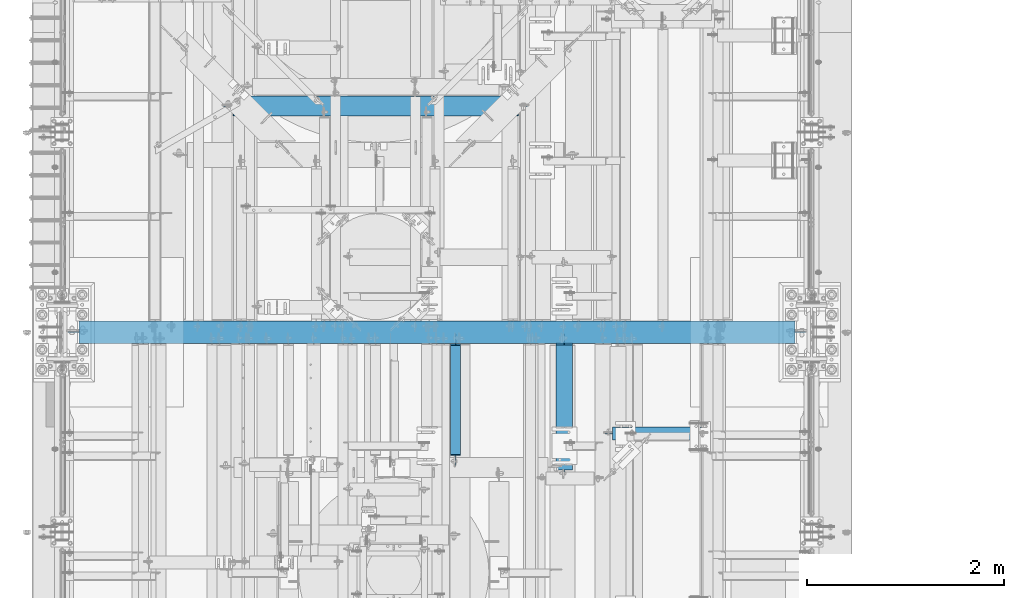
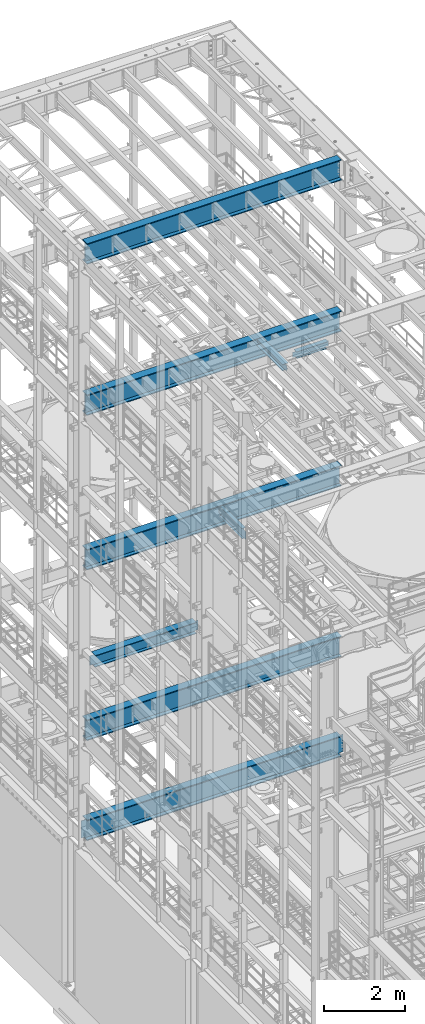
# One storey, part 1045 of 1876: 9 beams, 9 elements without a shape of their own.
"""IFC2X3 building model written with IfcOpenShell, lengths in millimetres."""

from ifc_helpers import new_model, si_unit, frame, origin_with_axes, place, context, subcontext, project, spatial, faceted_brep, material, type_object, element, aggregate, save


model = new_model("IFC2X3")

# Units and contexts
model_context = context("Model", 3, precision=1e-05, world=origin_with_axes())
body_context = subcontext(model_context, "Body", "Model", "MODEL_VIEW")
ifc_project = project(units=[si_unit("LENGTHUNIT", "METRE", prefix="MILLI"), si_unit("AREAUNIT", "SQUARE_METRE"), si_unit("VOLUMEUNIT", "CUBIC_METRE"), si_unit("MASSUNIT", "GRAM", prefix="KILO"), si_unit("TIMEUNIT", "SECOND"), si_unit("PLANEANGLEUNIT", "RADIAN"), si_unit("SOLIDANGLEUNIT", "STERADIAN"), si_unit("THERMODYNAMICTEMPERATUREUNIT", "DEGREE_CELSIUS"), si_unit("LUMINOUSINTENSITYUNIT", "LUMEN")], contexts=[model_context])

# Site, building, storey
site_placement = place(None, origin_with_axes())
site = spatial("IfcSite", under=ifc_project, at=site_placement, CompositionType="ELEMENT")
building_placement = place(site_placement, origin_with_axes())
building = spatial("IfcBuilding", under=site, at=building_placement, Name="Undefined", CompositionType="ELEMENT")
storey_placement = place(building_placement, origin_with_axes())
storey = spatial("IfcBuildingStorey", under=building, at=storey_placement, Name="Undefined", CompositionType="ELEMENT", Elevation=0.0)

# Assembly, beam
assembly_1_placement = place(storey_placement, origin_with_axes())
assembly_1 = element("IfcElementAssembly", 1, at=assembly_1_placement, inside=storey, Name="BEAM", AssemblyPlace="NOTDEFINED", PredefinedType="RIGID_FRAME")
ifc_material = material(Name="STEEL/A992")
beam_type_1 = type_object("IfcBeamType", Name="W8X24", PredefinedType="NOTDEFINED")
beam_1_placement = place(assembly_1_placement, frame((5105.39901450963, 6133.50589599609, 17883.1875), z_axis=(0.0, 0.0, 1.0), x_axis=(0.0, 1.0, 0.0)))
beam_1 = element("IfcBeam", 2, at=beam_1_placement, type_object=beam_type_1, material=ifc_material, Name="BEAM", ObjectType="W8X24", context=body_context, shape_type="Brep", body=[
    faceted_brep([(1374.57535400391, -82.5500000000002, -100.012500000001), (1374.57535400391, 82.5500000000002, -100.012500000001), (1374.57535400391, 82.5500000000002, -93.662499809263), (1374.57535400391, -82.5500000000002, -93.662499809263), (1375.2069007324, -3.17500000000018, -90.4874999999993), (1375.2069007324, -82.5500000000002, -90.4874999999993), (1375.2069007324, 82.5500000000002, -90.4874999999993), (1375.2069007324, 3.17500000000018, -90.4874999999993), (1375.54208392649, 3.17500000000018, -88.8024202912165), (1375.54208392649, -3.17500000000018, -88.8024202912165), (1378.29509782697, 3.17500000000018, -84.6822438230629), (1378.29509782697, -3.17500000000018, -84.6822438230629), (1382.41527429513, 3.17500000000018, -81.9292299225854), (1382.41527429513, -3.17500000000018, -81.9292299225854), (1387.27535381317, 3.17500000000018, -80.9624999999978), (1387.27535381317, -3.17500000000018, -80.9624999999978), (1466.65035400391, -3.17500000000018, -80.9624999999978), (1466.65035400391, 3.17500000000018, -80.9624999999978), (85.7249999999985, 3.17500000000018, 90.4874999999993), (85.7249999999985, 82.5500000000002, 90.4874999999993), (1358.70035400391, 82.5500000000002, 90.4874999999993), (1358.70035400391, 3.17500000000018, 90.4874999999993), (107.949999999998, -3.17500000000018, -87.3124998092644), (107.949999999998, 3.17500000000018, -87.3124998092644), (107.950000000001, 3.17500000000018, -90.48749980926), (107.949999999998, 82.5500000000002, -90.4874999999993), (107.949999999998, 82.5500000000002, -100.012500000001), (107.949999999998, -82.5500000000002, -100.012500000001), (107.949999999998, -82.5500000000002, -90.4874999999993), (107.950000000001, -3.17500000000018, -90.48749980926), (106.98327007741, -3.17500000000018, -82.452420291218), (106.98327007741, 3.17500000000018, -82.452420291218), (104.230256176932, -3.17500000000018, -78.3322438230643), (104.230256176932, 3.17500000000018, -78.3322438230643), (100.110079708778, -3.17500000000018, -75.5792299225868), (100.110079708778, 3.17500000000018, -75.5792299225868), (95.2500001907329, -3.17500000000018, -74.6124999999993), (95.2500001907329, 3.17500000000018, -74.6124999999993), (15.8749999999982, -3.17500000000018, -74.6124999999993), (15.8749999999982, 3.17500000000018, -74.6124999999993), (15.875, -3.17500000000018, 74.6125000000029), (15.875, 3.17500000000018, 74.6125000000029), (73.0250001907334, -3.17500000000018, 74.6124999999993), (73.0250001907334, 3.17500000000018, 74.6124999999993), (77.8850797087789, -3.17500000000018, 75.5792299225868), (77.8850797087789, 3.17500000000018, 75.5792299225868), (82.0052561769326, -3.17500000000018, 78.3322438230643), (82.0052561769326, 3.17500000000018, 78.3322438230643), (84.758270077411, -3.17500000000018, 82.452420291218), (84.758270077411, 3.17500000000018, 82.452420291218), (85.7249999999985, -3.17500000000018, 87.3124998092644), (85.7249999999985, 3.17500000000018, 87.3124998092644), (85.7249999999985, -82.5500000000002, 100.012500000001), (85.7249999999985, 82.5500000000002, 100.012500000001), (85.7249999999985, -3.17500000000018, 90.4874999999993), (85.7249999999985, -82.5500000000002, 90.4874999999993), (1358.70035400391, -3.17500000000018, 90.4874999999993), (1358.70035400391, -82.5500000000002, 90.4874999999993), (1358.70035400391, -82.5500000000002, 100.012500000001), (1358.70035400391, 82.5500000000002, 100.012500000001), (1358.70035400391, -3.17500000000018, 74.612499809271), (1358.70035400391, 3.17500000000018, 74.612499809271), (1359.66708392649, -3.17500000000018, 69.7524202912246), (1359.66708392649, 3.17500000000018, 69.7524202912246), (1362.42009782697, -3.17500000000018, 65.6322438230709), (1362.42009782697, 3.17500000000018, 65.6322438230709), (1366.54027429513, -3.17500000000018, 62.8792299225934), (1366.54027429513, 3.17500000000018, 62.8792299225934), (1371.40035381317, -3.17500000000018, 61.9125000000058), (1371.40035381317, 3.17500000000018, 61.9125000000058), (1466.65035400391, -3.17500000000018, 61.9125000000058), (1466.65035400391, 3.17500000000018, 61.9125000000058)], [[[0, 1, 2, 3]], [[4, 5, 3, 2, 6, 7, 8, 9]], [[9, 8, 10, 11]], [[11, 10, 12, 13]], [[13, 12, 14, 15]], [[16, 15, 14, 17]], [[18, 19, 20, 21]], [[22, 23, 24, 25, 26, 27, 28, 29]], [[30, 31, 23, 22]], [[32, 33, 31, 30]], [[34, 35, 33, 32]], [[36, 37, 35, 34]], [[38, 39, 37, 36]], [[40, 41, 39, 38]], [[42, 43, 41, 40]], [[44, 45, 43, 42]], [[46, 47, 45, 44]], [[48, 49, 47, 46]], [[50, 51, 49, 48]], [[52, 53, 19, 18, 51, 50, 54, 55]], [[55, 54, 56, 57]], [[52, 55, 57, 58]], [[53, 52, 58, 59]], [[19, 53, 59, 20]], [[58, 57, 56, 60, 61, 21, 20, 59]], [[62, 63, 61, 60]], [[64, 65, 63, 62]], [[66, 67, 65, 64]], [[68, 69, 67, 66]], [[70, 71, 69, 68]], [[71, 70, 16, 17]], [[12, 10, 8, 7, 24, 23, 31, 33, 35, 37, 39, 41, 43, 45, 47, 49, 51, 18, 21, 61, 63, 65, 67, 69, 71, 17, 14]], [[25, 24, 7, 6]], [[1, 26, 25, 6, 2]], [[27, 26, 1, 0]], [[28, 27, 0, 3, 5]], [[29, 28, 5, 4]], [[70, 68, 66, 64, 62, 60, 56, 54, 50, 48, 46, 44, 42, 40, 38, 36, 34, 32, 30, 22, 29, 4, 9, 11, 13, 15, 16]]]),
])
aggregate(assembly_1, [beam_1])

assembly_2_placement = place(storey_placement, origin_with_axes())
assembly_2 = element("IfcElementAssembly", 3, at=assembly_2_placement, inside=storey, Name="BEAM", AssemblyPlace="NOTDEFINED", PredefinedType="RIGID_FRAME")
beam_type_2 = type_object("IfcBeamType", Name="W12X16", PredefinedType="NOTDEFINED")
beam_2_placement = place(assembly_2_placement, frame((4000.5, 6115.05, 13157.2), z_axis=(0.0, 0.0, 1.0), x_axis=(0.0, 1.0, 0.0)))
beam_2 = element("IfcBeam", 4, at=beam_2_placement, type_object=beam_type_2, material=ifc_material, Name="BEAM", ObjectType="W12X16", context=body_context, shape_type="Brep", body=[
    faceted_brep([(148.431250000001, -3.17500000000018, -127.0), (148.431250000001, 3.17500000000018, -127.0), (237.331250190735, 3.17500000000018, -127.0), (237.331250190735, -3.17500000000018, -127.0), (242.19132970878, 3.17500000000018, -127.966729922588), (242.19132970878, -3.17500000000018, -127.966729922588), (246.311506176934, 3.17500000000018, -130.719743823067), (246.311506176934, -3.17500000000018, -130.719743823067), (249.064520077412, 3.17500000000018, -134.839920291221), (249.064520077412, -3.17500000000018, -134.839920291221), (250.03125, -3.17500000000018, -139.699999809265), (250.03125, 3.17500000000018, -139.699999809265), (250.031249999999, 3.17500000000018, -146.049999999999), (250.031249999999, 50.8000000000002, -146.049999999999), (250.031249999999, 50.8000000000002, -152.4), (250.031249999999, -50.8000000000002, -152.4), (250.031249999999, -50.8000000000002, -146.049999999999), (250.031249999999, -3.17500000000018, -146.049999999999), (1370.80625, 50.8000000000002, 146.049999999999), (1370.80625, 3.17500000000018, 146.049999999999), (262.73125, 3.17500000000018, 146.049999999999), (262.73125, 50.8000000000002, 146.049999999999), (250.031250190735, -3.17500000000018, 107.950000000001), (250.031250190735, 3.17500000000018, 107.950000000001), (148.431250000001, 3.17500000000018, 107.950000000001), (148.431250000001, -3.17500000000018, 107.950000000001), (254.89132970878, -3.17500000000018, 108.916729922588), (254.89132970878, 3.17500000000018, 108.916729922588), (259.011506176934, -3.17500000000018, 111.669743823066), (259.011506176934, 3.17500000000018, 111.669743823066), (261.764520077412, -3.17500000000018, 115.789920291219), (261.764520077412, 3.17500000000018, 115.789920291219), (262.73125, -3.17500000000018, 120.649999809266), (262.73125, 3.17500000000018, 120.649999809266), (1370.80625, -50.8000000000002, 152.4), (1370.80625, 50.8000000000002, 152.4), (262.73125, 50.8000000000002, 152.4), (262.73125, -50.8000000000002, 152.4), (1370.80625, -50.8000000000002, 146.049999999999), (262.73125, -50.8000000000002, 146.049999999999), (1370.80625, -3.17500000000018, 146.049999999999), (262.73125, -3.17500000000018, 146.049999999999), (1370.80625, -3.17500000000018, 126.999999809264), (1370.80625, 3.17500000000018, 126.999999809264), (1371.77297992259, -3.17500000000018, 122.139920291218), (1371.77297992259, 3.17500000000018, 122.139920291218), (1374.52599382306, -3.17500000000018, 118.019743823064), (1374.52599382306, 3.17500000000018, 118.019743823064), (1378.64617029122, -3.17500000000018, 115.266729922587), (1378.64617029122, 3.17500000000018, 115.266729922587), (1383.50624980926, -3.17500000000018, 114.299999999999), (1383.50624980926, 3.17500000000018, 114.299999999999), (1485.10625, -3.17500000000018, 114.299999999999), (1485.10625, 3.17500000000018, 114.299999999999), (1485.10625, -3.17500000000018, -127.0), (1485.10625, 3.17500000000018, -127.0), (1396.20624980926, -3.17500000000018, -127.0), (1396.20624980926, 3.17500000000018, -127.0), (1391.34617029122, -3.17500000000018, -127.966729922588), (1391.34617029122, 3.17500000000018, -127.966729922588), (1387.22599382306, -3.17500000000018, -130.719743823065), (1387.22599382306, 3.17500000000018, -130.719743823065), (1384.47297992259, -3.17500000000018, -134.839920291219), (1384.47297992259, 3.17500000000018, -134.839920291219), (1383.50625, -3.17500000000018, -139.699999809265), (1383.50625, 3.17500000000018, -139.699999809265), (1383.50625, -3.17500000000018, -146.049999999999), (1383.50625, -50.8000000000002, -146.049999999999), (1383.50625, -50.8000000000002, -152.4), (1383.50625, 50.8000000000002, -152.4), (1383.50625, 50.8000000000002, -146.049999999999), (1383.50625, 3.17500000000018, -146.049999999999)], [[[0, 1, 2, 3]], [[3, 2, 4, 5]], [[5, 4, 6, 7]], [[7, 6, 8, 9]], [[10, 11, 12, 13, 14, 15, 16, 17]], [[9, 8, 11, 10]], [[18, 19, 20, 21]], [[22, 23, 24, 25]], [[26, 27, 23, 22]], [[28, 29, 27, 26]], [[30, 31, 29, 28]], [[32, 33, 31, 30]], [[34, 35, 36, 37]], [[38, 34, 37, 39]], [[40, 38, 39, 41]], [[37, 36, 21, 20, 33, 32, 41, 39]], [[35, 18, 21, 36]], [[34, 38, 40, 42, 43, 19, 18, 35]], [[44, 45, 43, 42]], [[46, 47, 45, 44]], [[48, 49, 47, 46]], [[50, 51, 49, 48]], [[52, 53, 51, 50]], [[53, 52, 54, 55]], [[54, 56, 57, 55]], [[58, 59, 57, 56]], [[60, 61, 59, 58]], [[62, 63, 61, 60]], [[64, 65, 63, 62]], [[66, 67, 68, 69, 70, 71, 65, 64]], [[67, 66, 17, 16]], [[68, 67, 16, 15]], [[69, 68, 15, 14]], [[70, 69, 14, 13]], [[71, 70, 13, 12]], [[6, 4, 2, 1, 24, 23, 27, 29, 31, 33, 20, 19, 43, 45, 47, 49, 51, 53, 55, 57, 59, 61, 63, 65, 71, 12, 11, 8]], [[25, 24, 1, 0]], [[66, 64, 62, 60, 58, 56, 54, 52, 50, 48, 46, 44, 42, 40, 41, 32, 30, 28, 26, 22, 25, 0, 3, 5, 7, 9, 10, 17]]]),
])
aggregate(assembly_2, [beam_2])

assembly_3_placement = place(storey_placement, origin_with_axes())
assembly_3 = element("IfcElementAssembly", 5, at=assembly_3_placement, inside=storey, Name="BEAM", AssemblyPlace="NOTDEFINED", PredefinedType="RIGID_FRAME")
beam_type_3 = type_object("IfcBeamType", Name="W8X18", PredefinedType="NOTDEFINED")
beam_3_placement = place(assembly_3_placement, frame((5502.275, 6590.70589599609, 17880.0125), z_axis=(0.0, 0.0, 1.0), x_axis=(1.0, 0.0, 0.0)))
beam_3 = element("IfcBeam", 6, at=beam_3_placement, type_object=beam_type_3, material=ifc_material, Name="BEAM", ObjectType="W8X18", context=body_context, shape_type="Brep", body=[
    faceted_brep([(955.675000113963, -3.17500000000018, -95.25), (955.675000113963, -66.6750000000002, -95.25), (955.675000113963, -66.6750000000002, -103.1875), (955.675000113963, 66.6750000000002, -103.1875), (955.675000113963, 66.6750000000002, -95.25), (955.675000113963, 3.17500000000018, -95.25), (955.675000113963, 3.17500000000018, -90.4874998092637), (955.675000113963, -3.17500000000018, -90.4874998092637), (956.64173003655, 3.17500000000018, -85.6274202912173), (956.64173003655, -3.17500000000018, -85.6274202912173), (959.394743937029, 3.17500000000018, -81.5072438230636), (959.394743937029, -3.17500000000018, -81.5072438230636), (963.514920405182, 3.17500000000018, -78.7542299225861), (963.514920405182, -3.17500000000018, -78.7542299225861), (968.374999923228, 3.17500000000018, -77.7874999999985), (968.374999923228, -3.17500000000018, -77.7874999999985), (1047.75000011396, -3.17500000000018, -77.7874999999985), (1047.75000011396, 3.17500000000018, -77.7874999999985), (95.25, 3.17500000000018, 95.25), (95.25, 66.6750000000002, 95.25), (1000.12500011396, 66.6750000000002, 95.25), (1000.12500011396, 3.17500000000018, 95.25), (107.950000000001, -3.17500000000018, -90.48749980926), (107.950000000001, 3.17500000000018, -90.48749980926), (107.950000000001, 3.17500000000018, -95.25), (107.950000000001, 66.6750000000002, -95.25), (107.950000000001, 66.6750000000002, -103.1875), (107.950000000001, -66.6750000000002, -103.1875), (107.950000000001, -66.6750000000002, -95.25), (107.950000000001, -3.17500000000018, -95.25), (106.983270077413, -3.17500000000018, -85.6274202912136), (106.983270077413, 3.17500000000018, -85.6274202912136), (104.230256176935, -3.17500000000018, -81.50724382306), (104.230256176935, 3.17500000000018, -81.50724382306), (100.110079708781, -3.17500000000018, -78.7542299225825), (100.110079708781, 3.17500000000018, -78.7542299225825), (95.2500001907356, -3.17500000000018, -77.7874999999949), (95.2500001907356, 3.17500000000018, -77.7874999999949), (15.875, -3.17500000000018, -77.7874999999949), (15.875, 3.17500000000018, -77.7874999999949), (15.875, -3.17500000000018, 77.7874999999949), (15.875, 3.17500000000018, 77.7874999999949), (82.5500001907349, -3.17500000000018, 77.7874999999949), (82.5500001907349, 3.17500000000018, 77.7874999999949), (87.4100797087804, -3.17500000000018, 78.7542299225825), (87.4100797087804, 3.17500000000018, 78.7542299225825), (91.530256176934, -3.17500000000018, 81.50724382306), (91.530256176934, 3.17500000000018, 81.50724382306), (94.2832700774125, -3.17500000000018, 85.6274202912136), (94.2832700774125, 3.17500000000018, 85.6274202912136), (95.25, -3.17500000000018, 90.48749980926), (95.25, 3.17500000000018, 90.48749980926), (95.25, -66.6750000000002, 103.1875), (95.25, 66.6750000000002, 103.1875), (95.25, -3.17500000000018, 95.25), (95.25, -66.6750000000002, 95.25), (1000.12500011396, -3.17500000000018, 95.25), (1000.12500011396, -66.6750000000002, 95.25), (1000.12500011396, -66.6750000000002, 103.1875), (1000.12500011396, 66.6750000000002, 103.1875), (1000.12500011396, -3.17500000000018, 90.4874998092673), (1000.12500011396, 3.17500000000018, 90.4874998092673), (1001.09173003655, -3.17500000000018, 85.6274202912209), (1001.09173003655, 3.17500000000018, 85.6274202912209), (1003.84474393703, -3.17500000000018, 81.5072438230673), (1003.84474393703, 3.17500000000018, 81.5072438230673), (1007.96492040518, -3.17500000000018, 78.7542299225897), (1007.96492040518, 3.17500000000018, 78.7542299225897), (1012.82499992323, -3.17500000000018, 77.7875000000022), (1012.82499992323, 3.17500000000018, 77.7875000000022), (1047.75000011396, -3.17500000000018, 77.7875000000022), (1047.75000011396, 3.17500000000018, 77.7875000000022)], [[[0, 1, 2, 3, 4, 5, 6, 7]], [[7, 6, 8, 9]], [[9, 8, 10, 11]], [[11, 10, 12, 13]], [[13, 12, 14, 15]], [[16, 15, 14, 17]], [[18, 19, 20, 21]], [[22, 23, 24, 25, 26, 27, 28, 29]], [[30, 31, 23, 22]], [[32, 33, 31, 30]], [[34, 35, 33, 32]], [[36, 37, 35, 34]], [[38, 39, 37, 36]], [[40, 41, 39, 38]], [[42, 43, 41, 40]], [[44, 45, 43, 42]], [[46, 47, 45, 44]], [[48, 49, 47, 46]], [[50, 51, 49, 48]], [[52, 53, 19, 18, 51, 50, 54, 55]], [[55, 54, 56, 57]], [[52, 55, 57, 58]], [[53, 52, 58, 59]], [[19, 53, 59, 20]], [[58, 57, 56, 60, 61, 21, 20, 59]], [[62, 63, 61, 60]], [[64, 65, 63, 62]], [[66, 67, 65, 64]], [[68, 69, 67, 66]], [[70, 71, 69, 68]], [[71, 70, 16, 17]], [[12, 10, 8, 6, 5, 24, 23, 31, 33, 35, 37, 39, 41, 43, 45, 47, 49, 51, 18, 21, 61, 63, 65, 67, 69, 71, 17, 14]], [[25, 24, 5, 4]], [[26, 25, 4, 3]], [[27, 26, 3, 2]], [[28, 27, 2, 1]], [[29, 28, 1, 0]], [[70, 68, 66, 64, 62, 60, 56, 54, 50, 48, 46, 44, 42, 40, 38, 36, 34, 32, 30, 22, 29, 0, 7, 9, 11, 13, 15, 16]]]),
])
aggregate(assembly_3, [beam_3])

assembly_4_placement = place(storey_placement, origin_with_axes())
assembly_4 = element("IfcElementAssembly", 7, at=assembly_4_placement, inside=storey, Name="BEAM", AssemblyPlace="NOTDEFINED", PredefinedType="RIGID_FRAME")
beam_type_4 = type_object("IfcBeamType", Name="W14X48", PredefinedType="NOTDEFINED")
beam_4_placement = place(assembly_4_placement, frame((1225.55, 9918.7, 7978.775), z_axis=(0.0, 0.0, 1.0), x_axis=(1.0, 0.0, 0.0)))
beam_4 = element("IfcBeam", 8, at=beam_4_placement, type_object=beam_type_4, material=ifc_material, Name="BEAM", ObjectType="W14X48", context=body_context, shape_type="Brep", body=[
    faceted_brep([(416.71875, -3.96875, -142.875), (416.71875, 3.96875, -142.875), (499.268750190735, 3.96875, -142.875), (499.268750190735, -3.96875, -142.875), (504.12882970878, 3.96875, -143.841729922588), (504.12882970878, -3.96875, -143.841729922588), (508.249006176934, 3.96875, -146.594743823066), (508.249006176934, -3.96875, -146.594743823066), (511.002020077412, 3.96875, -150.71492029122), (511.002020077412, -3.96875, -150.71492029122), (511.96875, -3.96875, -155.574999809265), (511.96875, 3.96875, -155.574999809265), (511.96875, 3.96875, -158.75), (511.96875, 101.6, -158.75), (511.96875, 101.6, -174.625), (511.96875, -101.6, -174.625), (511.96875, -101.6, -158.75), (511.96875, -3.96875, -158.75), (3405.98125, 101.6, 158.75), (3405.98125, 3.96875, 158.75), (518.31875, 3.96875, 158.75), (518.31875, 101.6, 158.75), (505.618750190735, -3.96875, 142.875), (505.618750190735, 3.96875, 142.875), (416.71875, 3.96875, 142.875), (416.71875, -3.96875, 142.875), (510.47882970878, -3.96875, 143.841729922588), (510.47882970878, 3.96875, 143.841729922588), (514.599006176934, -3.96875, 146.594743823066), (514.599006176934, 3.96875, 146.594743823066), (517.352020077412, -3.96875, 150.71492029122), (517.352020077412, 3.96875, 150.71492029122), (518.31875, -3.96875, 155.574999809265), (518.31875, 3.96875, 155.574999809265), (3405.98125, -101.6, 174.625), (3405.98125, 101.6, 174.625), (518.31875, 101.6, 174.625), (518.31875, -101.6, 174.625), (3405.98125, -101.6, 158.75), (518.31875, -101.6, 158.75), (3405.98125, -3.96875, 158.75), (518.31875, -3.96875, 158.75), (3405.98125, -3.96875, 155.574999809265), (3405.98125, 3.96875, 155.574999809265), (3406.94797992259, -3.96875, 150.71492029122), (3406.94797992259, 3.96875, 150.71492029122), (3409.70099382307, -3.96875, 146.594743823066), (3409.70099382307, 3.96875, 146.594743823066), (3413.82117029122, -3.96875, 143.841729922588), (3413.82117029122, 3.96875, 143.841729922588), (3418.68124980926, -3.96875, 142.875), (3418.68124980926, 3.96875, 142.875), (3507.58125, -3.96875, 142.875), (3507.58125, 3.96875, 142.875), (3507.58125, -3.96875, -142.875), (3507.58125, 3.96875, -142.875), (3425.03124980926, -3.96875, -142.875), (3425.03124980926, 3.96875, -142.875), (3420.17117029122, -3.96875, -143.841729922588), (3420.17117029122, 3.96875, -143.841729922588), (3416.05099382307, -3.96875, -146.594743823066), (3416.05099382307, 3.96875, -146.594743823066), (3413.29797992259, -3.96875, -150.71492029122), (3413.29797992259, 3.96875, -150.71492029122), (3412.33125, -3.96875, -155.574999809265), (3412.33125, 3.96875, -155.574999809265), (3412.33125, -3.96875, -158.75), (3412.33125, -101.6, -158.75), (3412.33125, -101.6, -174.625), (3412.33125, 101.6, -174.625), (3412.33125, 101.6, -158.75), (3412.33125, 3.96875, -158.75)], [[[0, 1, 2, 3]], [[3, 2, 4, 5]], [[5, 4, 6, 7]], [[7, 6, 8, 9]], [[10, 11, 12, 13, 14, 15, 16, 17]], [[9, 8, 11, 10]], [[18, 19, 20, 21]], [[22, 23, 24, 25]], [[26, 27, 23, 22]], [[28, 29, 27, 26]], [[30, 31, 29, 28]], [[32, 33, 31, 30]], [[34, 35, 36, 37]], [[38, 34, 37, 39]], [[40, 38, 39, 41]], [[37, 36, 21, 20, 33, 32, 41, 39]], [[35, 18, 21, 36]], [[34, 38, 40, 42, 43, 19, 18, 35]], [[44, 45, 43, 42]], [[46, 47, 45, 44]], [[48, 49, 47, 46]], [[50, 51, 49, 48]], [[52, 53, 51, 50]], [[53, 52, 54, 55]], [[54, 56, 57, 55]], [[58, 59, 57, 56]], [[60, 61, 59, 58]], [[62, 63, 61, 60]], [[64, 65, 63, 62]], [[66, 67, 68, 69, 70, 71, 65, 64]], [[67, 66, 17, 16]], [[68, 67, 16, 15]], [[69, 68, 15, 14]], [[70, 69, 14, 13]], [[71, 70, 13, 12]], [[6, 4, 2, 1, 24, 23, 27, 29, 31, 33, 20, 19, 43, 45, 47, 49, 51, 53, 55, 57, 59, 61, 63, 65, 71, 12, 11, 8]], [[25, 24, 1, 0]], [[66, 64, 62, 60, 58, 56, 54, 52, 50, 48, 46, 44, 42, 40, 41, 32, 30, 28, 26, 22, 25, 0, 3, 5, 7, 9, 10, 17]]]),
])
aggregate(assembly_4, [beam_4])

assembly_5_placement = place(storey_placement, origin_with_axes())
assembly_5 = element("IfcElementAssembly", 9, at=assembly_5_placement, inside=storey, Name="BEAM", AssemblyPlace="NOTDEFINED", PredefinedType="RIGID_FRAME")
beam_type_5 = type_object("IfcBeamType", Name="W24X103", PredefinedType="NOTDEFINED")
beam_5_placement = place(assembly_5_placement, frame((0.0, 7620.0, 17672.05), z_axis=(0.0, 0.0, 1.0), x_axis=(1.0, 0.0, 0.0)))
beam_5 = element("IfcBeam", 10, at=beam_5_placement, type_object=beam_type_5, material=ifc_material, Name="BEAM", ObjectType="W24X103", context=body_context, shape_type="Brep", body=[
    faceted_brep([(171.45, 114.3, -311.150000000001), (171.45, 114.3, -285.75), (7448.55, 114.3, -285.75), (7448.55, 114.3, -311.150000000001), (171.45, 7.14374999999995, -285.75), (7448.55, 7.14374999999995, -285.75), (171.45, 7.14374999999995, 285.75), (7448.55, 7.14374999999995, 285.75), (171.45, 114.3, 285.75), (7448.55, 114.3, 285.75), (171.45, 114.3, 311.150000000001), (7448.55, 114.3, 311.150000000001), (171.45, -114.3, 311.150000000001), (7448.55, -114.3, 311.150000000001), (171.45, -114.3, 285.75), (7448.55, -114.3, 285.75), (171.45, -7.14374999999995, 285.75), (7448.55, -7.14374999999995, 285.75), (171.45, -7.14374999999995, -285.75), (7448.55, -7.14374999999995, -285.75), (171.45, -114.3, -285.75), (7448.55, -114.3, -285.75), (171.45, -114.3, -311.150000000001), (7448.55, -114.3, -311.150000000001)], [[[0, 1, 2, 3]], [[1, 4, 5, 2]], [[4, 6, 7, 5]], [[6, 8, 9, 7]], [[8, 10, 11, 9]], [[10, 12, 13, 11]], [[12, 14, 15, 13]], [[14, 16, 17, 15]], [[16, 18, 19, 17]], [[18, 20, 21, 19]], [[20, 22, 23, 21]], [[22, 0, 3, 23]], [[5, 7, 9, 11, 13, 15, 17, 19, 21, 23, 3, 2]], [[22, 20, 18, 16, 14, 12, 10, 8, 6, 4, 1, 0]]]),
])
aggregate(assembly_5, [beam_5])

assembly_6_placement = place(storey_placement, origin_with_axes())
assembly_6 = element("IfcElementAssembly", 11, at=assembly_6_placement, inside=storey, Name="BEAM", AssemblyPlace="NOTDEFINED", PredefinedType="RIGID_FRAME")
beam_6_placement = place(assembly_6_placement, frame((0.0, 7620.0, 12998.45), z_axis=(0.0, 0.0, 1.0), x_axis=(1.0, 0.0, 0.0)))
beam_6 = element("IfcBeam", 12, at=beam_6_placement, type_object=beam_type_5, material=ifc_material, Name="BEAM", ObjectType="W24X103", context=body_context, shape_type="Brep", body=[
    faceted_brep([(171.45, 114.3, -311.150000000001), (171.45, 114.3, -285.75), (7448.55, 114.3, -285.75), (7448.55, 114.3, -311.150000000001), (171.45, 7.14374999999995, -285.75), (7448.55, 7.14374999999995, -285.75), (171.45, 7.14374999999995, 285.75), (7448.55, 7.14374999999995, 285.75), (171.45, 114.3, 285.75), (7448.55, 114.3, 285.75), (171.45, 114.3, 311.150000000001), (7448.55, 114.3, 311.150000000001), (171.45, -114.3, 311.150000000001), (7448.55, -114.3, 311.150000000001), (171.45, -114.3, 285.75), (7448.55, -114.3, 285.75), (171.45, -7.14374999999995, 285.75), (7448.55, -7.14374999999995, 285.75), (171.45, -7.14374999999995, -285.75), (7448.55, -7.14374999999995, -285.75), (171.45, -114.3, -285.75), (7448.55, -114.3, -285.75), (171.45, -114.3, -311.150000000001), (7448.55, -114.3, -311.150000000001)], [[[0, 1, 2, 3]], [[1, 4, 5, 2]], [[4, 6, 7, 5]], [[6, 8, 9, 7]], [[8, 10, 11, 9]], [[10, 12, 13, 11]], [[12, 14, 15, 13]], [[14, 16, 17, 15]], [[16, 18, 19, 17]], [[18, 20, 21, 19]], [[20, 22, 23, 21]], [[22, 0, 3, 23]], [[5, 7, 9, 11, 13, 15, 17, 19, 21, 23, 3, 2]], [[22, 20, 18, 16, 14, 12, 10, 8, 6, 4, 1, 0]]]),
])
aggregate(assembly_6, [beam_6])

assembly_7_placement = place(storey_placement, origin_with_axes())
assembly_7 = element("IfcElementAssembly", 13, at=assembly_7_placement, inside=storey, Name="BEAM", AssemblyPlace="NOTDEFINED", PredefinedType="RIGID_FRAME")
beam_7_placement = place(assembly_7_placement, frame((0.0, 7620.0, 7842.25), z_axis=(0.0, 0.0, 1.0), x_axis=(1.0, 0.0, 0.0)))
beam_7 = element("IfcBeam", 14, at=beam_7_placement, type_object=beam_type_5, material=ifc_material, Name="BEAM", ObjectType="W24X103", context=body_context, shape_type="Brep", body=[
    faceted_brep([(171.45, 114.3, -311.150000000001), (171.45, 114.3, -285.75), (7448.55, 114.3, -285.75), (7448.55, 114.3, -311.150000000001), (171.45, 7.14374999999995, -285.75), (7448.55, 7.14374999999995, -285.75), (171.45, 7.14374999999995, 285.75), (7448.55, 7.14374999999995, 285.75), (171.45, 114.3, 285.75), (7448.55, 114.3, 285.75), (171.45, 114.3, 311.150000000001), (7448.55, 114.3, 311.150000000001), (171.45, -114.3, 311.150000000001), (7448.55, -114.3, 311.150000000001), (171.45, -114.3, 285.75), (7448.55, -114.3, 285.75), (171.45, -7.14374999999995, 285.75), (7448.55, -7.14374999999995, 285.75), (171.45, -7.14374999999995, -285.75), (7448.55, -7.14374999999995, -285.75), (171.45, -114.3, -285.75), (7448.55, -114.3, -285.75), (171.45, -114.3, -311.150000000001), (7448.55, -114.3, -311.150000000001)], [[[0, 1, 2, 3]], [[1, 4, 5, 2]], [[4, 6, 7, 5]], [[6, 8, 9, 7]], [[8, 10, 11, 9]], [[10, 12, 13, 11]], [[12, 14, 15, 13]], [[14, 16, 17, 15]], [[16, 18, 19, 17]], [[18, 20, 21, 19]], [[20, 22, 23, 21]], [[22, 0, 3, 23]], [[5, 7, 9, 11, 13, 15, 17, 19, 21, 23, 3, 2]], [[22, 20, 18, 16, 14, 12, 10, 8, 6, 4, 1, 0]]]),
])
aggregate(assembly_7, [beam_7])

assembly_8_placement = place(storey_placement, origin_with_axes())
assembly_8 = element("IfcElementAssembly", 15, at=assembly_8_placement, inside=storey, Name="BEAM", AssemblyPlace="NOTDEFINED", PredefinedType="RIGID_FRAME")
beam_8_placement = place(assembly_8_placement, frame((0.0, 7620.0, 22244.05), z_axis=(0.0, 0.0, 1.0), x_axis=(1.0, 0.0, 0.0)))
beam_8 = element("IfcBeam", 16, at=beam_8_placement, type_object=beam_type_5, material=ifc_material, Name="BEAM", ObjectType="W24X103", context=body_context, shape_type="Brep", body=[
    faceted_brep([(171.45, 114.3, -311.150000000001), (171.45, 114.3, -285.75), (7448.55, 114.3, -285.75), (7448.55, 114.3, -311.150000000001), (171.45, 7.14374999999995, -285.75), (7448.55, 7.14374999999995, -285.75), (171.45, 7.14374999999995, 285.75), (7448.55, 7.14374999999995, 285.75), (171.45, 114.3, 285.75), (7448.55, 114.3, 285.75), (171.45, 114.3, 311.150000000001), (7448.55, 114.3, 311.150000000001), (171.45, -114.3, 311.150000000001), (7448.55, -114.3, 311.150000000001), (171.45, -114.3, 285.75), (7448.55, -114.3, 285.75), (171.45, -7.14374999999995, 285.75), (7448.55, -7.14374999999995, 285.75), (171.45, -7.14374999999995, -285.75), (7448.55, -7.14374999999995, -285.75), (171.45, -114.3, -285.75), (7448.55, -114.3, -285.75), (171.45, -114.3, -311.150000000001), (7448.55, -114.3, -311.150000000001)], [[[0, 1, 2, 3]], [[1, 4, 5, 2]], [[4, 6, 7, 5]], [[6, 8, 9, 7]], [[8, 10, 11, 9]], [[10, 12, 13, 11]], [[12, 14, 15, 13]], [[14, 16, 17, 15]], [[16, 18, 19, 17]], [[18, 20, 21, 19]], [[20, 22, 23, 21]], [[22, 0, 3, 23]], [[5, 7, 9, 11, 13, 15, 17, 19, 21, 23, 3, 2]], [[22, 20, 18, 16, 14, 12, 10, 8, 6, 4, 1, 0]]]),
])
aggregate(assembly_8, [beam_8])

assembly_9_placement = place(storey_placement, origin_with_axes())
assembly_9 = element("IfcElementAssembly", 17, at=assembly_9_placement, inside=storey, Name="BEAM", AssemblyPlace="NOTDEFINED", PredefinedType="RIGID_FRAME")
beam_9_placement = place(assembly_9_placement, frame((0.0, 7620.0, 4819.65), z_axis=(0.0, 0.0, 1.0), x_axis=(1.0, 0.0, 0.0)))
beam_9 = element("IfcBeam", 18, at=beam_9_placement, type_object=beam_type_5, material=ifc_material, Name="BEAM", ObjectType="W24X103", context=body_context, shape_type="Brep", body=[
    faceted_brep([(7443.7875, -7.14374999999995, -285.75), (7443.7875, -114.3, -285.75), (7443.7875, -114.3, -311.15), (7443.7875, 114.3, -311.15), (7443.7875, 114.3, -285.75), (7443.7875, 7.14374999999995, -285.75), (7443.7875, 7.14374999999995, -273.049999809265), (7443.7875, -7.14374999999995, -273.049999809265), (7444.75422992259, 7.14374999999995, -268.189920291219), (7444.75422992259, -7.14374999999995, -268.189920291219), (7447.50724382307, 7.14374999999995, -264.069743823065), (7447.50724382307, -7.14374999999995, -264.069743823065), (7451.62742029122, 7.14374999999995, -261.316729922587), (7451.62742029122, -7.14374999999995, -261.316729922587), (7456.48749980927, 7.14374999999995, -260.349999999999), (7456.48749980927, -7.14374999999995, -260.349999999999), (7558.0875, -7.14374999999995, -260.349999999999), (7558.0875, 7.14374999999995, -260.349999999999), (176.2125, 7.14374999999995, 285.75), (176.2125, 114.3, 285.75), (7443.7875, 114.3, 285.75), (7443.7875, 7.14374999999995, 285.75), (176.2125, -7.14374999999995, -273.049999809265), (176.2125, 7.14374999999995, -273.049999809265), (176.2125, 7.14374999999995, -285.75), (176.2125, 114.3, -285.75), (176.2125, 114.3, -311.15), (176.2125, -114.3, -311.15), (176.2125, -114.3, -285.75), (176.2125, -7.14374999999995, -285.75), (175.245770077412, -7.14374999999995, -268.189920291219), (175.245770077412, 7.14374999999995, -268.189920291219), (172.492756176934, -7.14374999999995, -264.069743823065), (172.492756176934, 7.14374999999995, -264.069743823065), (168.37257970878, -7.14374999999995, -261.316729922587), (168.37257970878, 7.14374999999995, -261.316729922587), (163.512500190734, -7.14374999999995, -260.349999999999), (163.512500190734, 7.14374999999995, -260.349999999999), (61.9125000000001, -7.14374999999995, -260.349999999999), (61.9125000000001, 7.14374999999995, -260.349999999999), (61.9125000000001, -7.14374999999995, 260.35), (61.9125000000001, 7.14374999999995, 260.35), (163.512500190734, -7.14374999999995, 260.35), (163.512500190734, 7.14374999999995, 260.35), (168.37257970878, -7.14374999999995, 261.316729922588), (168.37257970878, 7.14374999999995, 261.316729922588), (172.492756176934, -7.14374999999995, 264.069743823066), (172.492756176934, 7.14374999999995, 264.069743823066), (175.245770077412, -7.14374999999995, 268.18992029122), (175.245770077412, 7.14374999999995, 268.18992029122), (176.2125, -7.14374999999995, 273.049999809266), (176.2125, 7.14374999999995, 273.049999809266), (176.2125, -114.3, 311.15), (176.2125, 114.3, 311.15), (176.2125, -7.14374999999995, 285.75), (176.2125, -114.3, 285.75), (7443.7875, -7.14374999999995, 285.75), (7443.7875, -114.3, 285.75), (7443.7875, -114.3, 311.15), (7443.7875, 114.3, 311.15), (7443.7875, -7.14374999999995, 273.049999809266), (7443.7875, 7.14374999999995, 273.049999809266), (7444.75422992259, -7.14374999999995, 268.18992029122), (7444.75422992259, 7.14374999999995, 268.18992029122), (7447.50724382307, -7.14374999999995, 264.069743823066), (7447.50724382307, 7.14374999999995, 264.069743823066), (7451.62742029122, -7.14374999999995, 261.316729922588), (7451.62742029122, 7.14374999999995, 261.316729922588), (7456.48749980927, -7.14374999999995, 260.35), (7456.48749980927, 7.14374999999995, 260.35), (7558.0875, -7.14374999999995, 260.35), (7558.0875, 7.14374999999995, 260.35)], [[[0, 1, 2, 3, 4, 5, 6, 7]], [[7, 6, 8, 9]], [[9, 8, 10, 11]], [[11, 10, 12, 13]], [[13, 12, 14, 15]], [[16, 15, 14, 17]], [[18, 19, 20, 21]], [[22, 23, 24, 25, 26, 27, 28, 29]], [[30, 31, 23, 22]], [[32, 33, 31, 30]], [[34, 35, 33, 32]], [[36, 37, 35, 34]], [[38, 39, 37, 36]], [[40, 41, 39, 38]], [[42, 43, 41, 40]], [[44, 45, 43, 42]], [[46, 47, 45, 44]], [[48, 49, 47, 46]], [[50, 51, 49, 48]], [[52, 53, 19, 18, 51, 50, 54, 55]], [[55, 54, 56, 57]], [[52, 55, 57, 58]], [[53, 52, 58, 59]], [[19, 53, 59, 20]], [[58, 57, 56, 60, 61, 21, 20, 59]], [[62, 63, 61, 60]], [[64, 65, 63, 62]], [[66, 67, 65, 64]], [[68, 69, 67, 66]], [[70, 71, 69, 68]], [[71, 70, 16, 17]], [[12, 10, 8, 6, 5, 24, 23, 31, 33, 35, 37, 39, 41, 43, 45, 47, 49, 51, 18, 21, 61, 63, 65, 67, 69, 71, 17, 14]], [[25, 24, 5, 4]], [[26, 25, 4, 3]], [[27, 26, 3, 2]], [[28, 27, 2, 1]], [[29, 28, 1, 0]], [[70, 68, 66, 64, 62, 60, 56, 54, 50, 48, 46, 44, 42, 40, 38, 36, 34, 32, 30, 22, 29, 0, 7, 9, 11, 13, 15, 16]]]),
])
aggregate(assembly_9, [beam_9])

save(model, "model.ifc")
